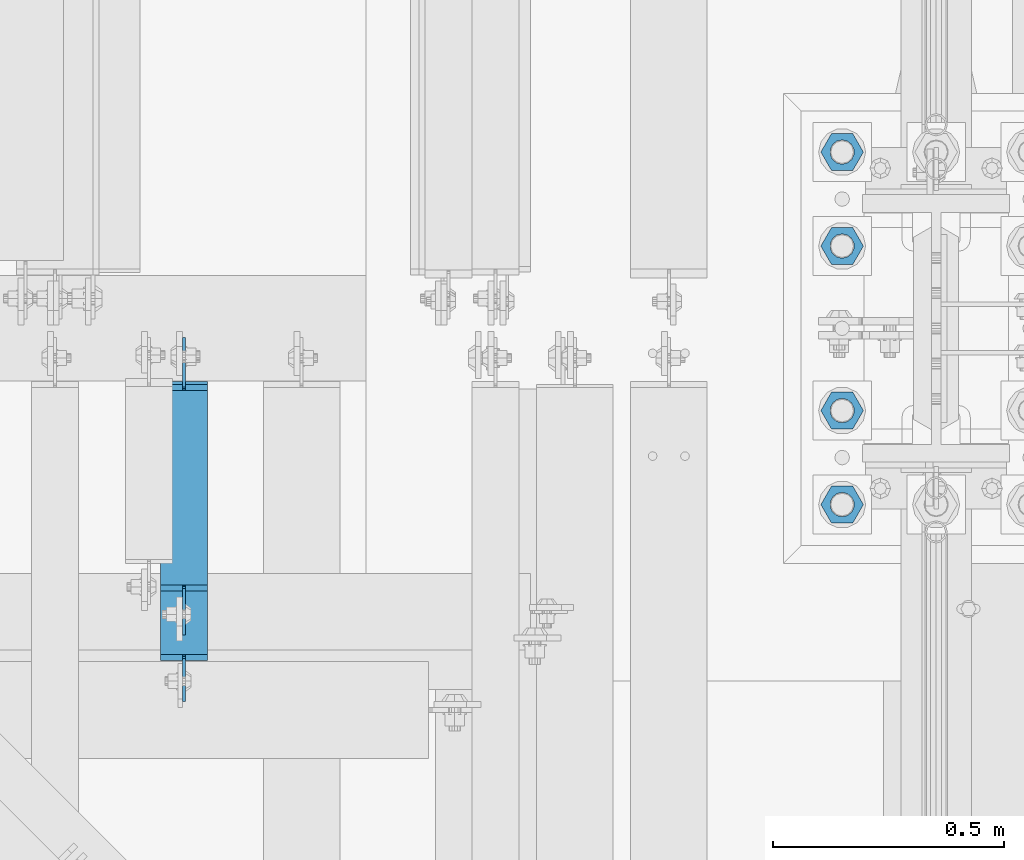
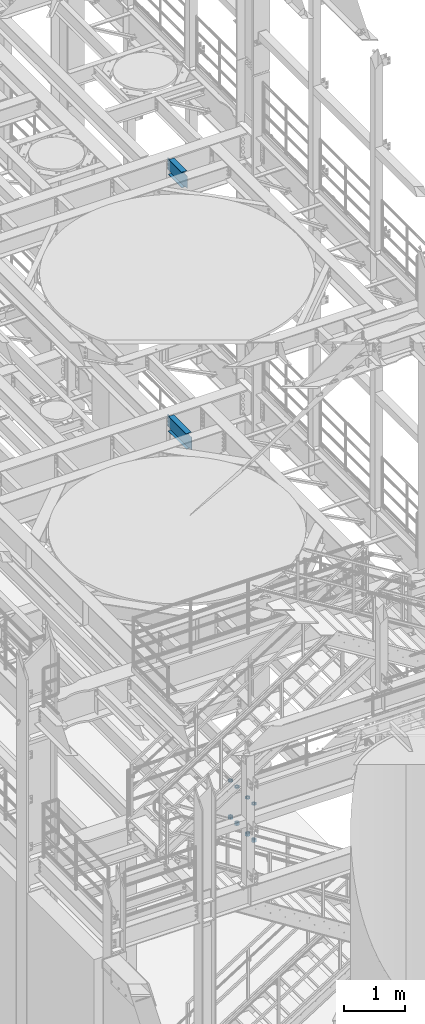
# One storey, part 1242 of 1876: 10 beams, 3 elements without a shape of their own.
"""IFC2X3 building model written with IfcOpenShell, lengths in millimetres."""

import ifcopenshell
import ifcopenshell.guid

model = None  # the IFC model being written
_history = None  # IfcOwnerHistory: only IFC2X3 demands one
_inside = {}  # id of a spatial element -> (the spatial element, [elements in it])
_under = {}  # id of a project, library or spatial element -> (it, [spatial elements below it])
_declared = {}  # id of a project -> (the project, [libraries it declares])
_typed = {}  # id of a type object -> (the type object, [elements of that type])
_made_of = {}  # id of a material, layer set ... -> (it, [elements and type objects made of it])


def new_model(schema):
    """Start an empty IFC model of exactly this schema.

    Asked for "IFC4X3", IfcOpenShell would pick the latest addendum, in which some entities
    have other attributes; the version numbers below select the first issue.
    IFC2X3 requires an IfcOwnerHistory on every rooted entity: one is made here for all.
    """
    global model, _history
    if schema == "IFC4X3":
        model = ifcopenshell.file(schema_version=(4, 3, 0, 0))
    else:
        model = ifcopenshell.file(schema=schema)
    _inside.clear()
    _under.clear()
    _declared.clear()
    _typed.clear()
    _made_of.clear()
    _history = None
    if model.schema == "IFC2X3":
        org = make("IfcOrganization", Name="unknown")
        user = make(
            "IfcPersonAndOrganization",
            ThePerson=make("IfcPerson", FamilyName="unknown"),
            TheOrganization=org,
        )
        app = make(
            "IfcApplication",
            ApplicationDeveloper=org,
            Version="unknown",
            ApplicationFullName="unknown",
            ApplicationIdentifier="unknown",
        )
        _history = make(
            "IfcOwnerHistory",
            OwningUser=user,
            OwningApplication=app,
            ChangeAction="ADDED",
            CreationDate=0,
        )
    return model


def make(cls, **values):
    """One entity of the class cls with the attributes given. An attribute that is None is left unset."""
    return model.create_entity(
        cls, **{name: value for name, value in values.items() if value is not None}
    )


def rooted(cls, **values):
    """An entity with a GlobalId (a new one), such as an element, a storey or a relation."""
    return make(cls, GlobalId=ifcopenshell.guid.new(), OwnerHistory=_history, **values)


def si_unit(unit_type, name, prefix=None):
    """IfcSIUnit, for example si_unit("LENGTHUNIT", "METRE", prefix="MILLI")."""
    return make("IfcSIUnit", UnitType=unit_type, Prefix=prefix, Name=name)


def assignment(units):
    """IfcUnitAssignment: the units of a project."""
    return None if units is None else make("IfcUnitAssignment", Units=units)


def point(xyz):
    """IfcCartesianPoint."""
    return None if xyz is None else make("IfcCartesianPoint", Coordinates=xyz)


def direction(xyz):
    """IfcDirection."""
    return None if xyz is None else make("IfcDirection", DirectionRatios=xyz)


def frame(location, z_axis=None, x_axis=None):
    """IfcAxis2Placement3D, a coordinate frame: its origin and axes. An axis left out is left unset."""
    return make(
        "IfcAxis2Placement3D",
        Location=point(location),
        Axis=direction(z_axis),
        RefDirection=direction(x_axis),
    )


def origin_with_axes():
    """The frame at (0, 0, 0) with the z axis (0, 0, 1) and the x axis (1, 0, 0) written out."""
    return frame((0.0, 0.0, 0.0), z_axis=(0.0, 0.0, 1.0), x_axis=(1.0, 0.0, 0.0))


def place(relative_to, where):
    """IfcLocalPlacement: puts the frame where relative to a parent placement (None: the world)."""
    return make(
        "IfcLocalPlacement", PlacementRelTo=relative_to, RelativePlacement=where
    )


def context(
    kind, dimensions, precision=None, world=None, true_north=None, identifier=None
):
    """IfcGeometricRepresentationContext, for example the 3D "Model" context."""
    return make(
        "IfcGeometricRepresentationContext",
        ContextIdentifier=identifier,
        ContextType=kind,
        CoordinateSpaceDimension=dimensions,
        Precision=precision,
        WorldCoordinateSystem=world,
        TrueNorth=true_north,
    )


def subcontext(parent, identifier, kind, view, scale=None):
    """IfcGeometricRepresentationSubContext, for example "Body" below "Model"."""
    return make(
        "IfcGeometricRepresentationSubContext",
        ContextIdentifier=identifier,
        ContextType=kind,
        ParentContext=parent,
        TargetScale=scale,
        TargetView=view,
    )


def project(units=None, contexts=None):
    """IfcProject with its units and contexts."""
    return rooted(
        "IfcProject",
        Name="project",
        RepresentationContexts=contexts,
        UnitsInContext=assignment(units),
    )


def spatial(cls, under=None, at=None, **own):
    """A site, building, storey or space (cls), placed at a placement, below another one or the project."""
    s = rooted(cls, ObjectPlacement=at, **own)
    if under is not None:
        _under.setdefault(under.id(), (under, []))[1].append(s)
    return s


def faces_of(points, faces, orient=None, outer=None):
    """IfcFace entities. A face is a list of loops; a loop is a list of indices into points, from 0.

    orient and outer hold one flag for each loop. By default every Orientation is true, the
    first loop of a face is its IfcFaceOuterBound and the others are IfcFaceBound.
    """
    made = []
    for i, loops in enumerate(faces):
        bounds = []
        for j, loop in enumerate(loops):
            is_outer = j == 0 if outer is None else outer[i][j]
            bounds.append(
                make(
                    "IfcFaceOuterBound" if is_outer else "IfcFaceBound",
                    Bound=make("IfcPolyLoop", Polygon=[points[k] for k in loop]),
                    Orientation=True if orient is None else orient[i][j],
                )
            )
        made.append(make("IfcFace", Bounds=bounds))
    return made


def faceted_brep(points, faces, orient=None, outer=None, voids=None):
    """IfcFacetedBrep: a solid bounded by flat faces; with voids (closed shells), ...WithVoids."""
    shared = [point(p) for p in points]
    hull = make("IfcClosedShell", CfsFaces=faces_of(shared, faces, orient, outer))
    if voids is None:
        return make("IfcFacetedBrep", Outer=hull)
    return make(
        "IfcFacetedBrepWithVoids",
        Outer=hull,
        Voids=[
            make(cls, CfsFaces=faces_of(shared, fs, o, b)) for cls, fs, o, b in voids
        ],
    )


def shape(context_of_items, identifier, shape_type, items):
    """IfcShapeRepresentation: the items that make up one representation, for example the "Body"."""
    return make(
        "IfcShapeRepresentation",
        ContextOfItems=context_of_items,
        RepresentationIdentifier=identifier,
        RepresentationType=shape_type,
        Items=items,
    )


def material(Name=None, Category=None):
    """IfcMaterial."""
    return make("IfcMaterial", Name=Name, Category=Category)


def made_of(thing, what):
    """Note that an element or type object is made of a material, layer set ...; save() writes the relation."""
    if what is not None:
        _made_of.setdefault(what.id(), (what, []))[1].append(thing)
    return thing


def type_object(cls, material=None, **own):
    """A type object (cls), such as IfcWallType, which elements share."""
    return made_of(rooted(cls, **own), material)


def element(
    cls,
    number,
    at=None,
    inside=None,
    cuts=None,
    type_object=None,
    material=None,
    context=None,
    identifier="Body",
    shape_type=None,
    held_by="IfcProductDefinitionShape",
    body=None,
    shapes=None,
    **own,
):
    """One element of the class cls, such as IfcWall. Its Tag is "e" and its number.

    at: its placement. inside: the storey or other place that contains it. cuts: it is an
    opening in that element (IfcRelVoidsElement). A single representation is given by context,
    identifier, shape_type and body (its items); several are given by shapes. held_by: the class
    of the entity that holds the representations. save() writes the other relations.
    """
    e = rooted(cls, Tag="e%d" % number, ObjectPlacement=at, **own)
    if body is not None:
        shapes = [shape(context, identifier, shape_type, body)]
    if shapes is not None:
        e.Representation = make(held_by, Representations=shapes)
    if inside is not None:
        _inside.setdefault(inside.id(), (inside, []))[1].append(e)
    if cuts is not None:
        rooted(
            "IfcRelVoidsElement", RelatingBuildingElement=cuts, RelatedOpeningElement=e
        )
    if type_object is not None:
        _typed.setdefault(type_object.id(), (type_object, []))[1].append(e)
    return made_of(e, material)


def aggregate(whole, parts):
    """IfcRelAggregates: a whole, such as a stair, and the parts it consists of."""
    return rooted("IfcRelAggregates", RelatingObject=whole, RelatedObjects=parts)


def save(model, path):
    """Write the relations noted so far, then the file.

    IfcRelAggregates (storeys below a building ...), IfcRelContainedInSpatialStructure (elements
    in a storey), IfcRelDefinesByType, IfcRelAssociatesMaterial and IfcRelDeclares: one each for
    every whole, place, type object, material and project.
    """
    for whole, parts in _under.values():
        aggregate(whole, parts)
    for where, things in _inside.values():
        rooted(
            "IfcRelContainedInSpatialStructure",
            RelatedElements=things,
            RelatingStructure=where,
        )
    for kind, things in _typed.values():
        rooted("IfcRelDefinesByType", RelatedObjects=things, RelatingType=kind)
    for what, things in _made_of.values():
        rooted("IfcRelAssociatesMaterial", RelatedObjects=things, RelatingMaterial=what)
    for by, libraries in _declared.values():
        rooted("IfcRelDeclares", RelatingContext=by, RelatedDefinitions=libraries)
    model.write(path)


model = new_model("IFC2X3")

# Units and contexts
model_context = context("Model", 3, precision=1e-05, world=origin_with_axes())
body_context = subcontext(model_context, "Body", "Model", "MODEL_VIEW")
ifc_project = project(units=[si_unit("LENGTHUNIT", "METRE", prefix="MILLI"), si_unit("AREAUNIT", "SQUARE_METRE"), si_unit("VOLUMEUNIT", "CUBIC_METRE"), si_unit("MASSUNIT", "GRAM", prefix="KILO"), si_unit("TIMEUNIT", "SECOND"), si_unit("PLANEANGLEUNIT", "RADIAN"), si_unit("SOLIDANGLEUNIT", "STERADIAN"), si_unit("THERMODYNAMICTEMPERATUREUNIT", "DEGREE_CELSIUS"), si_unit("LUMINOUSINTENSITYUNIT", "LUMEN")], contexts=[model_context])

# Site, building, storey
site_placement = place(None, origin_with_axes())
site = spatial("IfcSite", under=ifc_project, at=site_placement, CompositionType="ELEMENT")
building_placement = place(site_placement, origin_with_axes())
building = spatial("IfcBuilding", under=site, at=building_placement, Name="Undefined", CompositionType="ELEMENT")
storey_placement = place(building_placement, origin_with_axes())
storey = spatial("IfcBuildingStorey", under=building, at=storey_placement, Name="Undefined", CompositionType="ELEMENT", Elevation=0.0)

# Assembly, beam
assembly_1_placement = place(storey_placement, origin_with_axes())
assembly_1 = element("IfcElementAssembly", 1, at=assembly_1_placement, inside=storey, Name="BEAM", AssemblyPlace="NOTDEFINED", PredefinedType="RIGID_FRAME")
ifc_material_1 = material(Name="STEEL/A992")
beam_type_1 = type_object("IfcBeamType", Name="W12X16", PredefinedType="NOTDEFINED")
beam_1_placement = place(assembly_1_placement, frame((5994.4, 762.0, 13157.2), z_axis=(0.0, 0.0, 1.0), x_axis=(0.0, 1.0, 0.0)))
beam_1 = element("IfcBeam", 2, at=beam_1_placement, type_object=beam_type_1, material=ifc_material_1, Name="BEAM", ObjectType="W12X16", context=body_context, shape_type="Brep", body=[
    faceted_brep([(99.2187500000005, -3.17500000000018, -127.0), (99.2187500000005, 3.17500000000018, -127.0), (181.768750190735, 3.17500000000018, -127.0), (181.768750190735, -3.17500000000018, -127.0), (186.628829708781, 3.17500000000018, -127.966729922588), (186.628829708781, -3.17500000000018, -127.966729922588), (190.749006176934, 3.17500000000018, -130.719743823065), (190.749006176934, -3.17500000000018, -130.719743823065), (193.502020077412, 3.17500000000018, -134.839920291219), (193.502020077412, -3.17500000000018, -134.839920291219), (194.46875, -3.17500000000018, -139.699999809265), (194.46875, 3.17500000000018, -139.699999809265), (194.46875, 3.17500000000018, -146.049999999999), (194.46875, 50.8000000000002, -146.049999999999), (194.46875, 50.8000000000002, -152.4), (194.46875, -50.8000000000002, -152.4), (194.46875, -50.8000000000002, -146.049999999999), (194.46875, -3.17500000000018, -146.049999999999), (627.85625, 50.8000000000002, 146.049999999999), (627.85625, 3.17500000000018, 146.049999999999), (207.16875, 3.17500000000018, 146.049999999999), (207.16875, 50.8000000000002, 146.049999999999), (194.468750190735, -3.17500000000018, 114.299999999999), (194.468750190735, 3.17500000000018, 114.299999999999), (99.2187500000005, 3.17500000000018, 114.299999999999), (99.2187500000005, -3.17500000000018, 114.299999999999), (199.328829708781, -3.17500000000018, 115.266729922587), (199.328829708781, 3.17500000000018, 115.266729922587), (203.449006176934, -3.17500000000018, 118.019743823064), (203.449006176934, 3.17500000000018, 118.019743823064), (206.202020077412, -3.17500000000018, 122.139920291218), (206.202020077412, 3.17500000000018, 122.139920291218), (207.16875, -3.17500000000018, 126.999999809264), (207.16875, 3.17500000000018, 126.999999809264), (627.85625, -50.8000000000002, 152.4), (627.85625, 50.8000000000002, 152.4), (207.16875, 50.8000000000002, 152.4), (207.16875, -50.8000000000002, 152.4), (627.85625, -50.8000000000002, 146.049999999999), (207.16875, -50.8000000000002, 146.049999999999), (627.85625, -3.17500000000018, 146.049999999999), (207.16875, -3.17500000000018, 146.049999999999), (627.85625, -3.17500000000018, 126.999999809264), (627.85625, 3.17500000000018, 126.999999809264), (628.822979922588, -3.17500000000018, 122.139920291218), (628.822979922588, 3.17500000000018, 122.139920291218), (631.575993823066, -3.17500000000018, 118.019743823064), (631.575993823066, 3.17500000000018, 118.019743823064), (635.696170291219, -3.17500000000018, 115.266729922587), (635.696170291219, 3.17500000000018, 115.266729922587), (640.556249809265, -3.17500000000018, 114.299999999999), (640.556249809265, 3.17500000000018, 114.299999999999), (742.15625, -3.17500000000018, 114.299999999999), (742.15625, 3.17500000000018, 114.299999999999), (742.15625, -3.17500000000018, -126.999999999996), (742.15625, 3.17500000000018, -126.999999999996), (653.256249809265, -3.17500000000018, -127.0), (653.256249809265, 3.17500000000018, -127.0), (648.39617029122, -3.17500000000018, -127.966729922588), (648.39617029122, 3.17500000000018, -127.966729922588), (644.275993823066, -3.17500000000018, -130.719743823065), (644.275993823066, 3.17500000000018, -130.719743823065), (641.522979922588, -3.17500000000018, -134.839920291219), (641.522979922588, 3.17500000000018, -134.839920291219), (640.55625, -3.17500000000018, -139.699999809265), (640.55625, 3.17500000000018, -139.699999809265), (640.55625, -3.17500000000018, -146.049999999999), (640.55625, -50.8000000000002, -146.049999999999), (640.55625, -50.8000000000002, -152.4), (640.55625, 50.8000000000002, -152.4), (640.55625, 50.8000000000002, -146.049999999999), (640.55625, 3.17500000000018, -146.049999999999)], [[[0, 1, 2, 3]], [[3, 2, 4, 5]], [[5, 4, 6, 7]], [[7, 6, 8, 9]], [[10, 11, 12, 13, 14, 15, 16, 17]], [[9, 8, 11, 10]], [[18, 19, 20, 21]], [[22, 23, 24, 25]], [[26, 27, 23, 22]], [[28, 29, 27, 26]], [[30, 31, 29, 28]], [[32, 33, 31, 30]], [[34, 35, 36, 37]], [[38, 34, 37, 39]], [[40, 38, 39, 41]], [[37, 36, 21, 20, 33, 32, 41, 39]], [[35, 18, 21, 36]], [[34, 38, 40, 42, 43, 19, 18, 35]], [[44, 45, 43, 42]], [[46, 47, 45, 44]], [[48, 49, 47, 46]], [[50, 51, 49, 48]], [[52, 53, 51, 50]], [[53, 52, 54, 55]], [[54, 56, 57, 55]], [[58, 59, 57, 56]], [[60, 61, 59, 58]], [[62, 63, 61, 60]], [[64, 65, 63, 62]], [[66, 67, 68, 69, 70, 71, 65, 64]], [[67, 66, 17, 16]], [[68, 67, 16, 15]], [[69, 68, 15, 14]], [[70, 69, 14, 13]], [[71, 70, 13, 12]], [[6, 4, 2, 1, 24, 23, 27, 29, 31, 33, 20, 19, 43, 45, 47, 49, 51, 53, 55, 57, 59, 61, 63, 65, 71, 12, 11, 8]], [[25, 24, 1, 0]], [[66, 64, 62, 60, 58, 56, 54, 52, 50, 48, 46, 44, 42, 40, 41, 32, 30, 28, 26, 22, 25, 0, 3, 5, 7, 9, 10, 17]]]),
])
aggregate(assembly_1, [beam_1])

assembly_2_placement = place(storey_placement, origin_with_axes())
assembly_2 = element("IfcElementAssembly", 3, at=assembly_2_placement, inside=storey, Name="BEAM", AssemblyPlace="NOTDEFINED", PredefinedType="RIGID_FRAME")
beam_2_placement = place(assembly_2_placement, frame((5994.4, 863.6, 8001.0), z_axis=(0.0, 0.0, 1.0), x_axis=(0.0, 1.0, 0.0)))
beam_2 = element("IfcBeam", 4, at=beam_2_placement, type_object=beam_type_1, material=ifc_material_1, Name="BEAM", ObjectType="W12X16", context=body_context, shape_type="Brep", body=[
    faceted_brep([(-146.645312, -3.17500000000018, -126.999999999999), (-146.645312, 3.17500000000018, -126.999999999999), (-70.4453118092653, 3.17500000000018, -126.999999999999), (-70.4453118092653, -3.17500000000018, -126.999999999999), (-65.5852322912197, 3.17500000000018, -127.966729922587), (-65.5852322912197, -3.17500000000018, -127.966729922587), (-61.465055823066, 3.17500000000018, -130.719743823065), (-61.465055823066, -3.17500000000018, -130.719743823065), (-58.712041922588, 3.17500000000018, -134.839920291219), (-58.712041922588, -3.17500000000018, -134.839920291219), (-57.7453120000001, -3.17500000000018, -139.699999809264), (-57.7453120000001, 3.17500000000018, -139.699999809264), (-57.7453120000001, 3.17500000000018, -146.05), (-57.7453120000001, 50.8000000000002, -146.05), (-57.7453120000001, 50.8000000000002, -152.4), (-57.7453120000001, -50.8000000000002, -152.4), (-57.7453120000001, -50.8000000000002, -146.05), (-57.7453120000001, -3.17500000000018, -146.05), (532.60625, 50.8000000000002, 146.05), (532.60625, 3.17500000000018, 146.05), (-45.0453120000001, 3.17500000000018, 146.05), (-45.0453120000001, 50.8000000000002, 146.05), (-57.7453118092652, -3.17500000000018, 120.650000000001), (-57.7453118092652, 3.17500000000018, 120.650000000001), (-146.645312, 3.17500000000018, 120.650000000001), (-146.645312, -3.17500000000018, 120.650000000001), (-52.8852322912196, -3.17500000000018, 121.616729922588), (-52.8852322912196, 3.17500000000018, 121.616729922588), (-48.7650558230659, -3.17500000000018, 124.369743823067), (-48.7650558230659, 3.17500000000018, 124.369743823067), (-46.012041922588, -3.17500000000018, 128.48992029122), (-46.012041922588, 3.17500000000018, 128.48992029122), (-45.0453120000001, -3.17500000000018, 133.349999809266), (-45.0453120000001, 3.17500000000018, 133.349999809266), (532.60625, -50.8000000000002, 152.4), (532.60625, 50.8000000000002, 152.4), (-45.0453120000001, 50.8000000000002, 152.4), (-45.0453120000001, -50.8000000000002, 152.4), (532.60625, -50.8000000000002, 146.05), (-45.0453120000001, -50.8000000000002, 146.05), (532.60625, -3.17500000000018, 146.05), (-45.0453120000001, -3.17500000000018, 146.05), (532.60625, -3.17500000000018, 126.999999809264), (532.60625, 3.17500000000018, 126.999999809264), (533.572979922587, -3.17500000000018, 122.139920291219), (533.572979922587, 3.17500000000018, 122.139920291219), (536.325993823065, -3.17500000000018, 118.019743823065), (536.325993823065, 3.17500000000018, 118.019743823065), (540.446170291219, -3.17500000000018, 115.266729922587), (540.446170291219, 3.17500000000018, 115.266729922587), (545.306249809265, -3.17500000000018, 114.299999999999), (545.306249809265, 3.17500000000018, 114.299999999999), (640.556249809265, -3.17500000000018, 114.299999999999), (640.556249809265, 3.17500000000018, 114.299999999999), (640.556249999999, -3.17500000000018, -127.000000000001), (640.556249999999, 3.17500000000018, -127.000000000001), (558.006249809265, -3.17500000000018, -127.000000000001), (558.006249809265, 3.17500000000018, -127.000000000001), (553.146170291219, -3.17500000000018, -127.966729922588), (553.146170291219, 3.17500000000018, -127.966729922588), (549.025993823066, -3.17500000000018, -130.719743823067), (549.025993823066, 3.17500000000018, -130.719743823067), (546.272979922587, -3.17500000000018, -134.839920291221), (546.272979922587, 3.17500000000018, -134.839920291221), (545.30625, -3.17500000000018, -139.699999809266), (545.30625, 3.17500000000018, -139.699999809266), (545.30625, -3.17500000000018, -146.05), (545.30625, -50.8000000000002, -146.05), (545.30625, -50.8000000000002, -152.4), (545.30625, 50.8000000000002, -152.4), (545.30625, 50.8000000000002, -146.05), (545.30625, 3.17500000000018, -146.05)], [[[0, 1, 2, 3]], [[3, 2, 4, 5]], [[5, 4, 6, 7]], [[7, 6, 8, 9]], [[10, 11, 12, 13, 14, 15, 16, 17]], [[9, 8, 11, 10]], [[18, 19, 20, 21]], [[22, 23, 24, 25]], [[26, 27, 23, 22]], [[28, 29, 27, 26]], [[30, 31, 29, 28]], [[32, 33, 31, 30]], [[34, 35, 36, 37]], [[38, 34, 37, 39]], [[40, 38, 39, 41]], [[37, 36, 21, 20, 33, 32, 41, 39]], [[35, 18, 21, 36]], [[34, 38, 40, 42, 43, 19, 18, 35]], [[44, 45, 43, 42]], [[46, 47, 45, 44]], [[48, 49, 47, 46]], [[50, 51, 49, 48]], [[52, 53, 51, 50]], [[53, 52, 54, 55]], [[54, 56, 57, 55]], [[58, 59, 57, 56]], [[60, 61, 59, 58]], [[62, 63, 61, 60]], [[64, 65, 63, 62]], [[66, 67, 68, 69, 70, 71, 65, 64]], [[67, 66, 17, 16]], [[68, 67, 16, 15]], [[69, 68, 15, 14]], [[70, 69, 14, 13]], [[71, 70, 13, 12]], [[6, 4, 2, 1, 24, 23, 27, 29, 31, 33, 20, 19, 43, 45, 47, 49, 51, 53, 55, 57, 59, 61, 63, 65, 71, 12, 11, 8]], [[25, 24, 1, 0]], [[66, 64, 62, 60, 58, 56, 54, 52, 50, 48, 46, 44, 42, 40, 41, 32, 30, 28, 26, 22, 25, 0, 3, 5, 7, 9, 10, 17]]]),
])
aggregate(assembly_2, [beam_2])

# Assembly, beams
assembly_3_placement = place(storey_placement, origin_with_axes())
assembly_3 = element("IfcElementAssembly", 5, at=assembly_3_placement, inside=storey, Name="TEMPLATE", AssemblyPlace="NOTDEFINED", PredefinedType="RIGID_FRAME")
ifc_material_2 = material(Name="STEEL/A563")
beam_type_2 = type_object("IfcBeamType", Name="2_DIA. HALF_NUT", PredefinedType="NOTDEFINED")
beam_3_placement = place(assembly_3_placement, frame((7416.8, 1904.99999847412, 33.3375), z_axis=(0.0, -1.0, 0.0), x_axis=(0.0, 0.0, -1.0)))
beam_3 = element("IfcBeam", 6, at=beam_3_placement, type_object=beam_type_2, material=ifc_material_2, Name="NUT", ObjectType="2_DIA. HALF_NUT", context=body_context, shape_type="Brep", body=[
    faceted_brep([(0.0, -46.0369987487793, 9.09494701772928e-13), (0.0, -23.0184993743896, -39.869213104248), (25.4, -23.0184993743896, -39.869213104248), (25.4, -46.0369987487793, 9.09494701772928e-13), (0.0, 23.0184993743896, -39.869213104248), (25.4, 23.0184993743896, -39.869213104248), (0.0, 46.0369987487793, -9.09494701772928e-13), (25.4, 46.0369987487793, -9.09494701772928e-13), (0.0, 23.0184993743896, 39.869213104248), (25.4, 23.0184993743896, 39.869213104248), (0.0, -23.0184993743896, 39.869213104248), (25.4, -23.0184993743896, 39.869213104248), (0.0, 0.0, 26.1940002441406), (0.0, 11.3650617044514, 23.5999013092769), (25.4, 11.3650617044514, 23.5999013092769), (25.4, 0.0, 26.1940002441406), (0.0, 20.4791109456437, 16.3316083006703), (25.4, 20.4791109456437, 16.3316083006703), (0.0, 25.5370200498346, 5.82867859874477), (25.4, 25.5370200498346, 5.82867859874477), (0.0, 25.5370200498346, -5.82867859874477), (25.4, 25.5370200498346, -5.82867859874477), (0.0, 20.4791109456437, -16.3316083006703), (25.4, 20.4791109456437, -16.3316083006703), (0.0, 11.3650617044514, -23.5999013092769), (25.4, 11.3650617044514, -23.5999013092769), (0.0, 0.0, -26.1940002441406), (25.4, 0.0, -26.1940002441406), (0.0, -11.3650617044514, -23.5999013092769), (25.4, -11.3650617044514, -23.5999013092769), (0.0, -20.4791109456437, -16.3316083006703), (25.4, -20.4791109456437, -16.3316083006703), (0.0, -25.5370200498346, -5.82867859874477), (25.4, -25.5370200498346, -5.82867859874477), (0.0, -25.5370200498346, 5.82867859874477), (25.4, -25.5370200498346, 5.82867859874477), (0.0, -20.4791109456437, 16.3316083006703), (25.4, -20.4791109456437, 16.3316083006703), (0.0, -11.3650617044514, 23.5999013092769), (25.4, -11.3650617044514, 23.5999013092769)], [[[0, 1, 2, 3]], [[1, 4, 5, 2]], [[4, 6, 7, 5]], [[6, 8, 9, 7]], [[8, 10, 11, 9]], [[10, 0, 3, 11]], [[12, 13, 14, 15]], [[13, 16, 17, 14]], [[16, 18, 19, 17]], [[18, 20, 21, 19]], [[20, 22, 23, 21]], [[22, 24, 25, 23]], [[24, 26, 27, 25]], [[26, 28, 29, 27]], [[28, 30, 31, 29]], [[30, 32, 33, 31]], [[32, 34, 35, 33]], [[34, 36, 37, 35]], [[36, 38, 39, 37]], [[38, 12, 15, 39]], [[5, 7, 9, 11, 3, 2], [17, 19, 21, 23, 25, 27, 29, 31, 33, 35, 37, 39, 15, 14]], [[10, 8, 6, 4, 1, 0], [38, 36, 34, 32, 30, 28, 26, 24, 22, 20, 18, 16, 13, 12]]]),
])
beam_4_placement = place(assembly_3_placement, frame((7416.8, 1701.79999847412, 33.3375), z_axis=(0.0, -1.0, 0.0), x_axis=(0.0, 0.0, -1.0)))
beam_4 = element("IfcBeam", 7, at=beam_4_placement, type_object=beam_type_2, material=ifc_material_2, Name="NUT", ObjectType="2_DIA. HALF_NUT", context=body_context, shape_type="Brep", body=[
    faceted_brep([(0.0, -46.0369987487793, 9.09494701772928e-13), (0.0, -23.0184993743896, -39.869213104248), (25.4, -23.0184993743896, -39.869213104248), (25.4, -46.0369987487793, 9.09494701772928e-13), (0.0, 23.0184993743896, -39.869213104248), (25.4, 23.0184993743896, -39.869213104248), (0.0, 46.0369987487793, -9.09494701772928e-13), (25.4, 46.0369987487793, -9.09494701772928e-13), (0.0, 23.0184993743896, 39.869213104248), (25.4, 23.0184993743896, 39.869213104248), (0.0, -23.0184993743896, 39.869213104248), (25.4, -23.0184993743896, 39.869213104248), (0.0, 0.0, 26.1940002441406), (0.0, 11.3650617044514, 23.5999013092769), (25.4, 11.3650617044514, 23.5999013092769), (25.4, 0.0, 26.1940002441406), (0.0, 20.4791109456437, 16.3316083006703), (25.4, 20.4791109456437, 16.3316083006703), (0.0, 25.5370200498346, 5.82867859874477), (25.4, 25.5370200498346, 5.82867859874477), (0.0, 25.5370200498346, -5.82867859874477), (25.4, 25.5370200498346, -5.82867859874477), (0.0, 20.4791109456437, -16.3316083006703), (25.4, 20.4791109456437, -16.3316083006703), (0.0, 11.3650617044514, -23.5999013092769), (25.4, 11.3650617044514, -23.5999013092769), (0.0, 0.0, -26.1940002441406), (25.4, 0.0, -26.1940002441406), (0.0, -11.3650617044514, -23.5999013092769), (25.4, -11.3650617044514, -23.5999013092769), (0.0, -20.4791109456437, -16.3316083006703), (25.4, -20.4791109456437, -16.3316083006703), (0.0, -25.5370200498346, -5.82867859874477), (25.4, -25.5370200498346, -5.82867859874477), (0.0, -25.5370200498346, 5.82867859874477), (25.4, -25.5370200498346, 5.82867859874477), (0.0, -20.4791109456437, 16.3316083006703), (25.4, -20.4791109456437, 16.3316083006703), (0.0, -11.3650617044514, 23.5999013092769), (25.4, -11.3650617044514, 23.5999013092769)], [[[0, 1, 2, 3]], [[1, 4, 5, 2]], [[4, 6, 7, 5]], [[6, 8, 9, 7]], [[8, 10, 11, 9]], [[10, 0, 3, 11]], [[12, 13, 14, 15]], [[13, 16, 17, 14]], [[16, 18, 19, 17]], [[18, 20, 21, 19]], [[20, 22, 23, 21]], [[22, 24, 25, 23]], [[24, 26, 27, 25]], [[26, 28, 29, 27]], [[28, 30, 31, 29]], [[30, 32, 33, 31]], [[32, 34, 35, 33]], [[34, 36, 37, 35]], [[36, 38, 39, 37]], [[38, 12, 15, 39]], [[5, 7, 9, 11, 3, 2], [17, 19, 21, 23, 25, 27, 29, 31, 33, 35, 37, 39, 15, 14]], [[10, 8, 6, 4, 1, 0], [38, 36, 34, 32, 30, 28, 26, 24, 22, 20, 18, 16, 13, 12]]]),
])
beam_5_placement = place(assembly_3_placement, frame((7416.8, 1346.19999847412, 33.3375), z_axis=(0.0, -1.0, 0.0), x_axis=(0.0, 0.0, -1.0)))
beam_5 = element("IfcBeam", 8, at=beam_5_placement, type_object=beam_type_2, material=ifc_material_2, Name="NUT", ObjectType="2_DIA. HALF_NUT", context=body_context, shape_type="Brep", body=[
    faceted_brep([(0.0, -46.0369987487793, 9.09494701772928e-13), (0.0, -23.0184993743896, -39.869213104248), (25.4, -23.0184993743896, -39.869213104248), (25.4, -46.0369987487793, 9.09494701772928e-13), (0.0, 23.0184993743896, -39.869213104248), (25.4, 23.0184993743896, -39.869213104248), (0.0, 46.0369987487793, -9.09494701772928e-13), (25.4, 46.0369987487793, -9.09494701772928e-13), (0.0, 23.0184993743896, 39.869213104248), (25.4, 23.0184993743896, 39.869213104248), (0.0, -23.0184993743896, 39.869213104248), (25.4, -23.0184993743896, 39.869213104248), (0.0, 0.0, 26.1940002441406), (0.0, 11.3650617044514, 23.5999013092769), (25.4, 11.3650617044514, 23.5999013092769), (25.4, 0.0, 26.1940002441406), (0.0, 20.4791109456437, 16.3316083006703), (25.4, 20.4791109456437, 16.3316083006703), (0.0, 25.5370200498346, 5.82867859874477), (25.4, 25.5370200498346, 5.82867859874477), (0.0, 25.5370200498346, -5.82867859874477), (25.4, 25.5370200498346, -5.82867859874477), (0.0, 20.4791109456437, -16.3316083006703), (25.4, 20.4791109456437, -16.3316083006703), (0.0, 11.3650617044514, -23.5999013092769), (25.4, 11.3650617044514, -23.5999013092769), (0.0, 0.0, -26.1940002441406), (25.4, 0.0, -26.1940002441406), (0.0, -11.3650617044514, -23.5999013092769), (25.4, -11.3650617044514, -23.5999013092769), (0.0, -20.4791109456437, -16.3316083006703), (25.4, -20.4791109456437, -16.3316083006703), (0.0, -25.5370200498346, -5.82867859874477), (25.4, -25.5370200498346, -5.82867859874477), (0.0, -25.5370200498346, 5.82867859874477), (25.4, -25.5370200498346, 5.82867859874477), (0.0, -20.4791109456437, 16.3316083006703), (25.4, -20.4791109456437, 16.3316083006703), (0.0, -11.3650617044514, 23.5999013092769), (25.4, -11.3650617044514, 23.5999013092769)], [[[0, 1, 2, 3]], [[1, 4, 5, 2]], [[4, 6, 7, 5]], [[6, 8, 9, 7]], [[8, 10, 11, 9]], [[10, 0, 3, 11]], [[12, 13, 14, 15]], [[13, 16, 17, 14]], [[16, 18, 19, 17]], [[18, 20, 21, 19]], [[20, 22, 23, 21]], [[22, 24, 25, 23]], [[24, 26, 27, 25]], [[26, 28, 29, 27]], [[28, 30, 31, 29]], [[30, 32, 33, 31]], [[32, 34, 35, 33]], [[34, 36, 37, 35]], [[36, 38, 39, 37]], [[38, 12, 15, 39]], [[5, 7, 9, 11, 3, 2], [17, 19, 21, 23, 25, 27, 29, 31, 33, 35, 37, 39, 15, 14]], [[10, 8, 6, 4, 1, 0], [38, 36, 34, 32, 30, 28, 26, 24, 22, 20, 18, 16, 13, 12]]]),
])
beam_6_placement = place(assembly_3_placement, frame((7416.8, 1142.99999847412, 33.3375), z_axis=(0.0, -1.0, 0.0), x_axis=(0.0, 0.0, -1.0)))
beam_6 = element("IfcBeam", 9, at=beam_6_placement, type_object=beam_type_2, material=ifc_material_2, Name="NUT", ObjectType="2_DIA. HALF_NUT", context=body_context, shape_type="Brep", body=[
    faceted_brep([(0.0, -46.0369987487793, 9.09494701772928e-13), (0.0, -23.0184993743896, -39.869213104248), (25.4, -23.0184993743896, -39.869213104248), (25.4, -46.0369987487793, 9.09494701772928e-13), (0.0, 23.0184993743896, -39.869213104248), (25.4, 23.0184993743896, -39.869213104248), (0.0, 46.0369987487793, -9.09494701772928e-13), (25.4, 46.0369987487793, -9.09494701772928e-13), (0.0, 23.0184993743896, 39.869213104248), (25.4, 23.0184993743896, 39.869213104248), (0.0, -23.0184993743896, 39.869213104248), (25.4, -23.0184993743896, 39.869213104248), (0.0, 0.0, 26.1940002441406), (0.0, 11.3650617044514, 23.5999013092769), (25.4, 11.3650617044514, 23.5999013092769), (25.4, 0.0, 26.1940002441406), (0.0, 20.4791109456437, 16.3316083006703), (25.4, 20.4791109456437, 16.3316083006703), (0.0, 25.5370200498346, 5.82867859874477), (25.4, 25.5370200498346, 5.82867859874477), (0.0, 25.5370200498346, -5.82867859874477), (25.4, 25.5370200498346, -5.82867859874477), (0.0, 20.4791109456437, -16.3316083006703), (25.4, 20.4791109456437, -16.3316083006703), (0.0, 11.3650617044514, -23.5999013092769), (25.4, 11.3650617044514, -23.5999013092769), (0.0, 0.0, -26.1940002441406), (25.4, 0.0, -26.1940002441406), (0.0, -11.3650617044514, -23.5999013092769), (25.4, -11.3650617044514, -23.5999013092769), (0.0, -20.4791109456437, -16.3316083006703), (25.4, -20.4791109456437, -16.3316083006703), (0.0, -25.5370200498346, -5.82867859874477), (25.4, -25.5370200498346, -5.82867859874477), (0.0, -25.5370200498346, 5.82867859874477), (25.4, -25.5370200498346, 5.82867859874477), (0.0, -20.4791109456437, 16.3316083006703), (25.4, -20.4791109456437, 16.3316083006703), (0.0, -11.3650617044514, 23.5999013092769), (25.4, -11.3650617044514, 23.5999013092769)], [[[0, 1, 2, 3]], [[1, 4, 5, 2]], [[4, 6, 7, 5]], [[6, 8, 9, 7]], [[8, 10, 11, 9]], [[10, 0, 3, 11]], [[12, 13, 14, 15]], [[13, 16, 17, 14]], [[16, 18, 19, 17]], [[18, 20, 21, 19]], [[20, 22, 23, 21]], [[22, 24, 25, 23]], [[24, 26, 27, 25]], [[26, 28, 29, 27]], [[28, 30, 31, 29]], [[30, 32, 33, 31]], [[32, 34, 35, 33]], [[34, 36, 37, 35]], [[36, 38, 39, 37]], [[38, 12, 15, 39]], [[5, 7, 9, 11, 3, 2], [17, 19, 21, 23, 25, 27, 29, 31, 33, 35, 37, 39, 15, 14]], [[10, 8, 6, 4, 1, 0], [38, 36, 34, 32, 30, 28, 26, 24, 22, 20, 18, 16, 13, 12]]]),
])
beam_type_3 = type_object("IfcBeamType", Name="2_HEAVY_HEX_NUT", PredefinedType="NOTDEFINED")
beam_7_placement = place(assembly_3_placement, frame((7416.8, 1142.99999847412, -685.799998474121), z_axis=(0.0, -1.0, 0.0), x_axis=(0.0, 0.0, -1.0)))
beam_7 = element("IfcBeam", 10, at=beam_7_placement, type_object=beam_type_3, material=ifc_material_2, Name="NUT", ObjectType="2_HEAVY_HEX_NUT", context=body_context, shape_type="Brep", body=[
    faceted_brep([(0.0, -46.0369987487793, 9.09494701772928e-13), (0.0, -23.0184993743896, -39.869213104248), (50.8, -23.0184993743896, -39.869213104248), (50.8, -46.0369987487793, 9.09494701772928e-13), (0.0, 23.0184993743896, -39.869213104248), (50.8, 23.0184993743896, -39.869213104248), (0.0, 46.0369987487793, -9.09494701772928e-13), (50.8, 46.0369987487793, -9.09494701772928e-13), (0.0, 23.0184993743896, 39.869213104248), (50.8, 23.0184993743896, 39.869213104248), (0.0, -23.0184993743896, 39.869213104248), (50.8, -23.0184993743896, 39.869213104248), (0.0, 0.0, 26.1940002441406), (0.0, 11.3650617044514, 23.5999013092769), (50.8, 11.3650617044513, 23.5999013092771), (50.8, 0.0, 26.1940002441406), (0.0, 20.4791109456437, 16.3316083006703), (50.8, 20.4791109456439, 16.3316083006703), (0.0, 25.5370200498346, 5.82867859874477), (50.8, 25.5370200498343, 5.82867859874455), (0.0, 25.5370200498346, -5.82867859874477), (50.8, 25.5370200498343, -5.82867859874455), (0.0, 20.4791109456437, -16.3316083006703), (50.8, 20.4791109456439, -16.3316083006703), (0.0, 11.3650617044514, -23.5999013092769), (50.8, 11.3650617044514, -23.5999013092771), (0.0, 0.0, -26.1940002441406), (50.8, 0.0, -26.1940002441406), (0.0, -11.3650617044514, -23.5999013092769), (50.8, -11.3650617044513, -23.5999013092771), (0.0, -20.4791109456437, -16.3316083006703), (50.8, -20.4791109456439, -16.3316083006703), (0.0, -25.5370200498346, -5.82867859874477), (50.8, -25.5370200498343, -5.82867859874455), (0.0, -25.5370200498346, 5.82867859874477), (50.8, -25.5370200498343, 5.82867859874455), (0.0, -20.4791109456437, 16.3316083006703), (50.8, -20.4791109456439, 16.3316083006703), (0.0, -11.3650617044514, 23.5999013092769), (50.8, -11.3650617044514, 23.5999013092771)], [[[0, 1, 2, 3]], [[1, 4, 5, 2]], [[4, 6, 7, 5]], [[6, 8, 9, 7]], [[8, 10, 11, 9]], [[10, 0, 3, 11]], [[12, 13, 14, 15]], [[13, 16, 17, 14]], [[16, 18, 19, 17]], [[18, 20, 21, 19]], [[20, 22, 23, 21]], [[22, 24, 25, 23]], [[24, 26, 27, 25]], [[26, 28, 29, 27]], [[28, 30, 31, 29]], [[30, 32, 33, 31]], [[32, 34, 35, 33]], [[34, 36, 37, 35]], [[36, 38, 39, 37]], [[38, 12, 15, 39]], [[5, 7, 9, 11, 3, 2], [17, 19, 21, 23, 25, 27, 29, 31, 33, 35, 37, 39, 15, 14]], [[10, 8, 6, 4, 1, 0], [38, 36, 34, 32, 30, 28, 26, 24, 22, 20, 18, 16, 13, 12]]]),
])
beam_8_placement = place(assembly_3_placement, frame((7416.8, 1346.19999847412, -685.799998474121), z_axis=(0.0, -1.0, 0.0), x_axis=(0.0, 0.0, -1.0)))
beam_8 = element("IfcBeam", 11, at=beam_8_placement, type_object=beam_type_3, material=ifc_material_2, Name="NUT", ObjectType="2_HEAVY_HEX_NUT", context=body_context, shape_type="Brep", body=[
    faceted_brep([(0.0, -46.0369987487793, 9.09494701772928e-13), (0.0, -23.0184993743896, -39.869213104248), (50.8, -23.0184993743896, -39.869213104248), (50.8, -46.0369987487793, 9.09494701772928e-13), (0.0, 23.0184993743896, -39.869213104248), (50.8, 23.0184993743896, -39.869213104248), (0.0, 46.0369987487793, -9.09494701772928e-13), (50.8, 46.0369987487793, -9.09494701772928e-13), (0.0, 23.0184993743896, 39.869213104248), (50.8, 23.0184993743896, 39.869213104248), (0.0, -23.0184993743896, 39.869213104248), (50.8, -23.0184993743896, 39.869213104248), (0.0, 0.0, 26.1940002441406), (0.0, 11.3650617044514, 23.5999013092769), (50.8, 11.3650617044513, 23.5999013092771), (50.8, 0.0, 26.1940002441406), (0.0, 20.4791109456437, 16.3316083006703), (50.8, 20.4791109456439, 16.3316083006703), (0.0, 25.5370200498346, 5.82867859874477), (50.8, 25.5370200498343, 5.82867859874455), (0.0, 25.5370200498346, -5.82867859874477), (50.8, 25.5370200498343, -5.82867859874455), (0.0, 20.4791109456437, -16.3316083006703), (50.8, 20.4791109456439, -16.3316083006703), (0.0, 11.3650617044514, -23.5999013092769), (50.8, 11.3650617044514, -23.5999013092771), (0.0, 0.0, -26.1940002441406), (50.8, 0.0, -26.1940002441406), (0.0, -11.3650617044514, -23.5999013092769), (50.8, -11.3650617044513, -23.5999013092771), (0.0, -20.4791109456437, -16.3316083006703), (50.8, -20.4791109456439, -16.3316083006703), (0.0, -25.5370200498346, -5.82867859874477), (50.8, -25.5370200498343, -5.82867859874455), (0.0, -25.5370200498346, 5.82867859874477), (50.8, -25.5370200498343, 5.82867859874455), (0.0, -20.4791109456437, 16.3316083006703), (50.8, -20.4791109456439, 16.3316083006703), (0.0, -11.3650617044514, 23.5999013092769), (50.8, -11.3650617044514, 23.5999013092771)], [[[0, 1, 2, 3]], [[1, 4, 5, 2]], [[4, 6, 7, 5]], [[6, 8, 9, 7]], [[8, 10, 11, 9]], [[10, 0, 3, 11]], [[12, 13, 14, 15]], [[13, 16, 17, 14]], [[16, 18, 19, 17]], [[18, 20, 21, 19]], [[20, 22, 23, 21]], [[22, 24, 25, 23]], [[24, 26, 27, 25]], [[26, 28, 29, 27]], [[28, 30, 31, 29]], [[30, 32, 33, 31]], [[32, 34, 35, 33]], [[34, 36, 37, 35]], [[36, 38, 39, 37]], [[38, 12, 15, 39]], [[5, 7, 9, 11, 3, 2], [17, 19, 21, 23, 25, 27, 29, 31, 33, 35, 37, 39, 15, 14]], [[10, 8, 6, 4, 1, 0], [38, 36, 34, 32, 30, 28, 26, 24, 22, 20, 18, 16, 13, 12]]]),
])
beam_9_placement = place(assembly_3_placement, frame((7416.8, 1701.79999847412, -685.799998474121), z_axis=(0.0, -1.0, 0.0), x_axis=(0.0, 0.0, -1.0)))
beam_9 = element("IfcBeam", 12, at=beam_9_placement, type_object=beam_type_3, material=ifc_material_2, Name="NUT", ObjectType="2_HEAVY_HEX_NUT", context=body_context, shape_type="Brep", body=[
    faceted_brep([(0.0, -46.0369987487793, 9.09494701772928e-13), (0.0, -23.0184993743896, -39.869213104248), (50.8, -23.0184993743896, -39.869213104248), (50.8, -46.0369987487793, 9.09494701772928e-13), (0.0, 23.0184993743896, -39.869213104248), (50.8, 23.0184993743896, -39.869213104248), (0.0, 46.0369987487793, -9.09494701772928e-13), (50.8, 46.0369987487793, -9.09494701772928e-13), (0.0, 23.0184993743896, 39.869213104248), (50.8, 23.0184993743896, 39.869213104248), (0.0, -23.0184993743896, 39.869213104248), (50.8, -23.0184993743896, 39.869213104248), (0.0, 0.0, 26.1940002441406), (0.0, 11.3650617044514, 23.5999013092769), (50.8, 11.3650617044513, 23.5999013092771), (50.8, 0.0, 26.1940002441406), (0.0, 20.4791109456437, 16.3316083006703), (50.8, 20.4791109456439, 16.3316083006703), (0.0, 25.5370200498346, 5.82867859874477), (50.8, 25.5370200498343, 5.82867859874455), (0.0, 25.5370200498346, -5.82867859874477), (50.8, 25.5370200498343, -5.82867859874455), (0.0, 20.4791109456437, -16.3316083006703), (50.8, 20.4791109456439, -16.3316083006703), (0.0, 11.3650617044514, -23.5999013092769), (50.8, 11.3650617044514, -23.5999013092771), (0.0, 0.0, -26.1940002441406), (50.8, 0.0, -26.1940002441406), (0.0, -11.3650617044514, -23.5999013092769), (50.8, -11.3650617044513, -23.5999013092771), (0.0, -20.4791109456437, -16.3316083006703), (50.8, -20.4791109456439, -16.3316083006703), (0.0, -25.5370200498346, -5.82867859874477), (50.8, -25.5370200498343, -5.82867859874455), (0.0, -25.5370200498346, 5.82867859874477), (50.8, -25.5370200498343, 5.82867859874455), (0.0, -20.4791109456437, 16.3316083006703), (50.8, -20.4791109456439, 16.3316083006703), (0.0, -11.3650617044514, 23.5999013092769), (50.8, -11.3650617044514, 23.5999013092771)], [[[0, 1, 2, 3]], [[1, 4, 5, 2]], [[4, 6, 7, 5]], [[6, 8, 9, 7]], [[8, 10, 11, 9]], [[10, 0, 3, 11]], [[12, 13, 14, 15]], [[13, 16, 17, 14]], [[16, 18, 19, 17]], [[18, 20, 21, 19]], [[20, 22, 23, 21]], [[22, 24, 25, 23]], [[24, 26, 27, 25]], [[26, 28, 29, 27]], [[28, 30, 31, 29]], [[30, 32, 33, 31]], [[32, 34, 35, 33]], [[34, 36, 37, 35]], [[36, 38, 39, 37]], [[38, 12, 15, 39]], [[5, 7, 9, 11, 3, 2], [17, 19, 21, 23, 25, 27, 29, 31, 33, 35, 37, 39, 15, 14]], [[10, 8, 6, 4, 1, 0], [38, 36, 34, 32, 30, 28, 26, 24, 22, 20, 18, 16, 13, 12]]]),
])
beam_10_placement = place(assembly_3_placement, frame((7416.8, 1904.99999847412, -685.799998474121), z_axis=(0.0, -1.0, 0.0), x_axis=(0.0, 0.0, -1.0)))
beam_10 = element("IfcBeam", 13, at=beam_10_placement, type_object=beam_type_3, material=ifc_material_2, Name="NUT", ObjectType="2_HEAVY_HEX_NUT", context=body_context, shape_type="Brep", body=[
    faceted_brep([(0.0, -46.0369987487793, 9.09494701772928e-13), (0.0, -23.0184993743896, -39.869213104248), (50.8, -23.0184993743896, -39.869213104248), (50.8, -46.0369987487793, 9.09494701772928e-13), (0.0, 23.0184993743896, -39.869213104248), (50.8, 23.0184993743896, -39.869213104248), (0.0, 46.0369987487793, -9.09494701772928e-13), (50.8, 46.0369987487793, -9.09494701772928e-13), (0.0, 23.0184993743896, 39.869213104248), (50.8, 23.0184993743896, 39.869213104248), (0.0, -23.0184993743896, 39.869213104248), (50.8, -23.0184993743896, 39.869213104248), (0.0, 0.0, 26.1940002441406), (0.0, 11.3650617044514, 23.5999013092769), (50.8, 11.3650617044513, 23.5999013092771), (50.8, 0.0, 26.1940002441406), (0.0, 20.4791109456437, 16.3316083006703), (50.8, 20.4791109456439, 16.3316083006703), (0.0, 25.5370200498346, 5.82867859874477), (50.8, 25.5370200498343, 5.82867859874455), (0.0, 25.5370200498346, -5.82867859874477), (50.8, 25.5370200498343, -5.82867859874455), (0.0, 20.4791109456437, -16.3316083006703), (50.8, 20.4791109456439, -16.3316083006703), (0.0, 11.3650617044514, -23.5999013092769), (50.8, 11.3650617044514, -23.5999013092771), (0.0, 0.0, -26.1940002441406), (50.8, 0.0, -26.1940002441406), (0.0, -11.3650617044514, -23.5999013092769), (50.8, -11.3650617044513, -23.5999013092771), (0.0, -20.4791109456437, -16.3316083006703), (50.8, -20.4791109456439, -16.3316083006703), (0.0, -25.5370200498346, -5.82867859874477), (50.8, -25.5370200498343, -5.82867859874455), (0.0, -25.5370200498346, 5.82867859874477), (50.8, -25.5370200498343, 5.82867859874455), (0.0, -20.4791109456437, 16.3316083006703), (50.8, -20.4791109456439, 16.3316083006703), (0.0, -11.3650617044514, 23.5999013092769), (50.8, -11.3650617044514, 23.5999013092771)], [[[0, 1, 2, 3]], [[1, 4, 5, 2]], [[4, 6, 7, 5]], [[6, 8, 9, 7]], [[8, 10, 11, 9]], [[10, 0, 3, 11]], [[12, 13, 14, 15]], [[13, 16, 17, 14]], [[16, 18, 19, 17]], [[18, 20, 21, 19]], [[20, 22, 23, 21]], [[22, 24, 25, 23]], [[24, 26, 27, 25]], [[26, 28, 29, 27]], [[28, 30, 31, 29]], [[30, 32, 33, 31]], [[32, 34, 35, 33]], [[34, 36, 37, 35]], [[36, 38, 39, 37]], [[38, 12, 15, 39]], [[5, 7, 9, 11, 3, 2], [17, 19, 21, 23, 25, 27, 29, 31, 33, 35, 37, 39, 15, 14]], [[10, 8, 6, 4, 1, 0], [38, 36, 34, 32, 30, 28, 26, 24, 22, 20, 18, 16, 13, 12]]]),
])
aggregate(assembly_3, [beam_3, beam_4, beam_5, beam_6, beam_7, beam_8, beam_9, beam_10])

save(model, "model.ifc")
